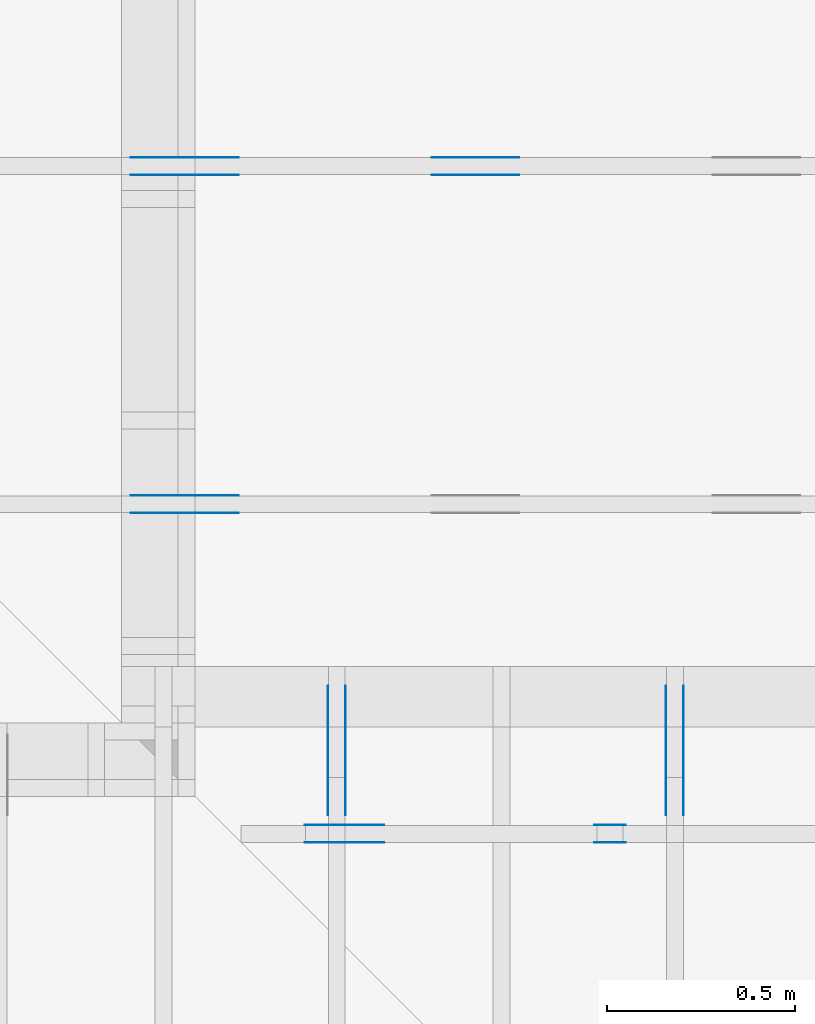
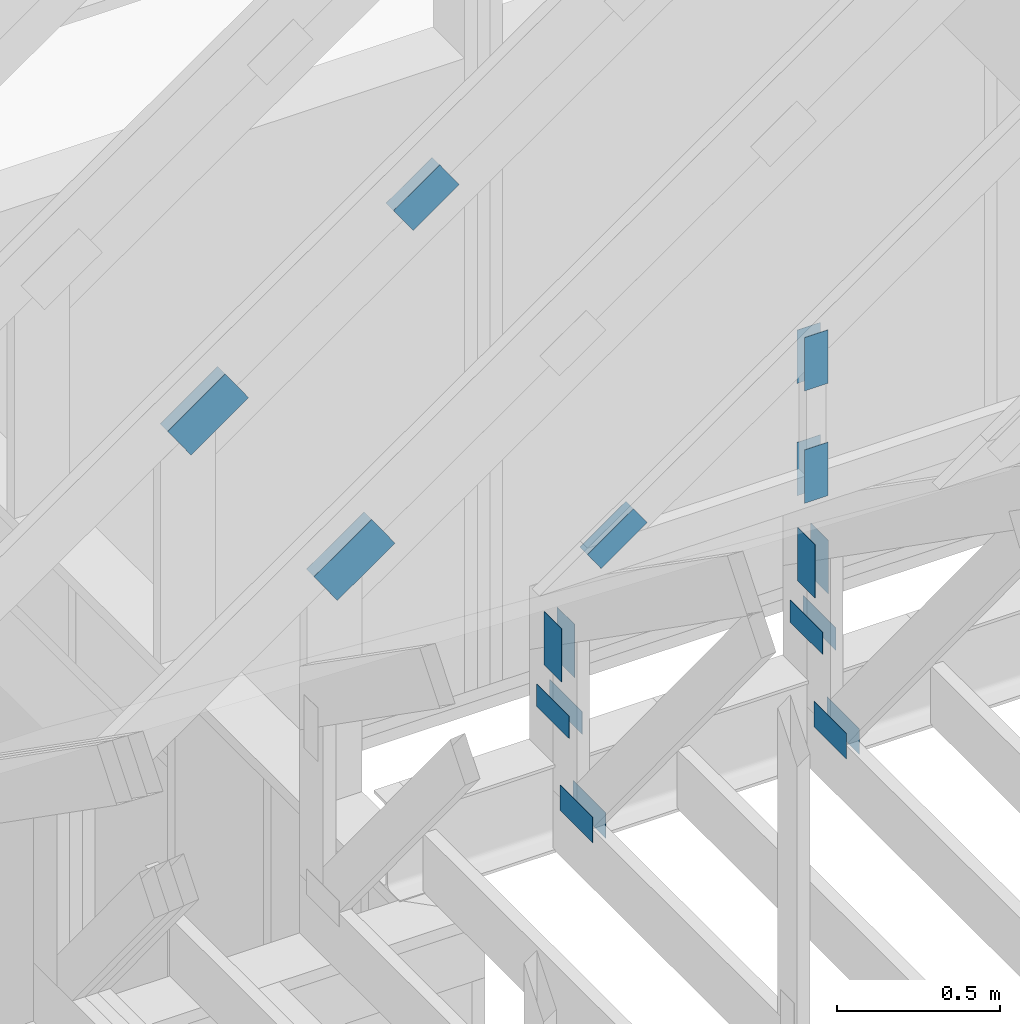
# One storey, part 61 of 70: 24 plates, 5 elements without a shape of their own.
"""IFC2X3 building model written with IfcOpenShell, lengths in millimetres."""

from ifc_helpers import new_model, si_unit, frame, origin, origin_with_axes, origin_2d, place, context, project, spatial, faceted_brep, element, aggregate, save


model = new_model("IFC2X3")

# Units and contexts
model_context = context("Model", 3, precision=1e-05, world=origin())
plan_context = context("Plan", 2, precision=1e-05, world=origin_2d())
ifc_project = project(units=[si_unit("LENGTHUNIT", "METRE", prefix="MILLI"), si_unit("AREAUNIT", "SQUARE_METRE"), si_unit("VOLUMEUNIT", "CUBIC_METRE"), si_unit("SOLIDANGLEUNIT", "STERADIAN"), si_unit("PLANEANGLEUNIT", "RADIAN"), si_unit("MASSUNIT", "GRAM"), si_unit("TIMEUNIT", "SECOND"), si_unit("THERMODYNAMICTEMPERATUREUNIT", "DEGREE_CELSIUS"), si_unit("LUMINOUSINTENSITYUNIT", "LUMEN")], contexts=[model_context, plan_context])

# Site, building, storey
site_placement = place(None, origin_with_axes())
site = spatial("IfcSite", under=ifc_project, at=site_placement, CompositionType="ELEMENT")
building_placement = place(site_placement, origin_with_axes())
building = spatial("IfcBuilding", under=site, at=building_placement, Name="Layout 1", CompositionType="ELEMENT")
storey_placement = place(building_placement, origin_with_axes())
storey = spatial("IfcBuildingStorey", under=building, at=storey_placement, Name="Storey 1", CompositionType="ELEMENT", Elevation=0.0)

# Assembly, plates
assembly_1_placement = place(storey_placement, frame((7000.0, 9505.0, 1.3776821480501744e-15), z_axis=(1.2246063538223773e-16, 1.0, 6.123031769111886e-17), x_axis=(-1.0, 1.2246063538223773e-16, 0.0)))
assembly_1 = element("IfcElementAssembly", 1, at=assembly_1_placement, inside=storey, Name="T4", AssemblyPlace="FACTORY", PredefinedType="TRUSS")
plate_1_placement = place(assembly_1_placement, frame((-24.003422903940475, 866.6521032421275, 0.0), z_axis=(0.0, 0.0, 1.0), x_axis=(-0.819152044288719, 0.5735764363514356, 0.0)))
plate_1 = element("IfcPlate", 2, at=plate_1_placement, context=model_context, shape_type="Brep", body=[
    faceted_brep([(250.0000000000001, 144.0, 1.3), (0.0, 144.0, 1.3), (0.0, 0.0, 1.3), (250.0, 0.0, 1.3), (0.0, 144.0, 0.0), (250.0000000000001, 144.0, 3.0615158845559444e-14), (250.0, 0.0, 3.061515884555943e-14), (0.0, 0.0, 0.0), (250.0, -4.592273826833915e-14, 2.8118638534165077e-30), (250.0, -4.5843138855340694e-14, 1.3), (1.4621692037765842e-32, 7.959941299845453e-17, 1.3), (0.0, 0.0, 0.0), (250.0, 143.9999999999999, -6.310887241768095e-30), (250.0, 143.9999999999999, 1.3), (250.0, 0.0, 1.3), (250.0, 0.0, 0.0), (0.0, 144.0, 0.0), (0.0, 144.0, 1.3), (250.00000000000009, 143.9999999999999, 1.3), (250.00000000000009, 143.9999999999999, -1.5777218104420236e-30), (0.0, 0.0, 0.0), (7.959941299845453e-17, -9.747794691843893e-33, 1.3), (1.7713930908040686e-14, 144.0, 1.3), (1.7634331495042233e-14, 144.0, -1.079755719711939e-30)], [[[0, 1, 2, 3]], [[4, 5, 6, 7]], [[8, 9, 10, 11]], [[12, 13, 14, 15]], [[16, 17, 18, 19]], [[20, 21, 22, 23]]]),
])
plate_2_placement = place(assembly_1_placement, frame((-24.003422903940475, 866.6521032421275, -46.3), z_axis=(0.0, 0.0, 1.0), x_axis=(-0.819152044288719, 0.5735764363514356, 0.0)))
plate_2 = element("IfcPlate", 3, at=plate_2_placement, context=model_context, shape_type="Brep", body=[
    faceted_brep([(250.0000000000001, 144.0, 1.2999999999999972), (0.0, 144.0, 1.2999999999999972), (0.0, 0.0, 1.2999999999999972), (250.0, 0.0, 1.2999999999999972), (0.0, 144.0, 0.0), (250.0000000000001, 144.0, 3.0615158845559444e-14), (250.0, 0.0, 3.061515884555943e-14), (0.0, 0.0, 0.0), (250.0, -4.592273826833915e-14, 2.8118638534165077e-30), (250.0, -4.5843138855340694e-14, 1.2999999999999972), (1.462169203776581e-32, 7.959941299845434e-17, 1.2999999999999972), (0.0, 0.0, 0.0), (250.0, 143.9999999999999, -6.310887241768095e-30), (250.0, 143.9999999999999, 1.2999999999999972), (250.0, 0.0, 1.2999999999999972), (250.0, 0.0, 0.0), (0.0, 144.0, 0.0), (0.0, 144.0, 1.2999999999999972), (250.00000000000009, 143.9999999999999, 1.2999999999999972), (250.00000000000009, 143.9999999999999, -1.5777218104420236e-30), (0.0, 0.0, 0.0), (7.959941299845434e-17, -9.747794691843873e-33, 1.2999999999999972), (1.7713930908040686e-14, 144.0, 1.2999999999999972), (1.7634331495042233e-14, 144.0, -1.079755719711939e-30)], [[[0, 1, 2, 3]], [[4, 5, 6, 7]], [[8, 9, 10, 11]], [[12, 13, 14, 15]], [[16, 17, 18, 19]], [[20, 21, 22, 23]]]),
])
plate_3_placement = place(assembly_1_placement, frame((-1058.7796737620245, 1430.0679887373412, 0.0), z_axis=(0.0, 0.0, 1.0), x_axis=(0.819152044288992, -0.5735764363510462, 0.0)))
plate_3 = element("IfcPlate", 4, at=plate_3_placement, context=model_context, shape_type="Brep", body=[
    faceted_brep([(200.00000000000023, 120.0, 1.3), (0.0, 120.0, 1.3), (2.2737367544323206e-13, 0.0, 1.3), (200.0, 0.0, 1.3), (0.0, 120.0, 0.0), (200.00000000000023, 120.0, 2.4492127076447574e-14), (200.0, 0.0, 2.4492127076447545e-14), (2.2737367544323206e-13, 0.0, 2.78443247639729e-29), (200.0, -3.673819061467132e-14, 2.249491082733206e-30), (200.0, -3.6658591201672864e-14, 1.3), (2.2737367544323206e-13, 7.959941299841276e-17, 1.3), (2.2737367544323206e-13, -4.176648714595935e-29, 2.5573752767891235e-45), (200.0, 120.0, -1.4199496293978212e-29), (200.0, 120.0, 1.3), (200.0, 0.0, 1.3), (200.0, 0.0, 0.0), (0.0, 120.0, 0.0), (-4.8738973459219465e-33, 120.0, 1.3), (200.00000000000023, 119.99999999999999, 1.3), (200.00000000000023, 119.99999999999999, 0.0), (2.2737367544323206e-13, 0.0, 0.0), (2.274532748562305e-13, 1.669984074232364e-31, 1.3), (-2.430497480793855e-14, 120.0, 1.3), (-2.4384574220936983e-14, 120.0, 1.4930752263106387e-30)], [[[0, 1, 2, 3]], [[4, 5, 6, 7]], [[8, 9, 10, 11]], [[12, 13, 14, 15]], [[16, 17, 18, 19]], [[20, 21, 22, 23]]]),
])
plate_4_placement = place(assembly_1_placement, frame((-1058.7796737620245, 1430.0679887373412, -46.300000000000004), z_axis=(0.0, 0.0, 1.0), x_axis=(0.819152044288992, -0.5735764363510462, 0.0)))
plate_4 = element("IfcPlate", 5, at=plate_4_placement, context=model_context, shape_type="Brep", body=[
    faceted_brep([(200.00000000000023, 120.0, 1.2999999999999972), (0.0, 120.0, 1.2999999999999972), (2.2737367544323206e-13, 0.0, 1.2999999999999972), (200.0, 0.0, 1.2999999999999972), (0.0, 120.0, 0.0), (200.00000000000023, 120.0, 2.4492127076447574e-14), (200.0, 0.0, 2.4492127076447545e-14), (2.2737367544323206e-13, 0.0, 2.78443247639729e-29), (200.0, -3.673819061467132e-14, 2.249491082733206e-30), (200.0, -3.6658591201672864e-14, 1.2999999999999972), (2.2737367544323206e-13, 7.959941299841258e-17, 1.2999999999999972), (2.2737367544323206e-13, -4.176648714595935e-29, 2.5573752767891235e-45), (200.0, 120.0, -1.4199496293978212e-29), (200.0, 120.0, 1.2999999999999972), (200.0, 0.0, 1.2999999999999972), (200.0, 0.0, 0.0), (0.0, 120.0, 0.0), (-4.873897345921936e-33, 120.0, 1.2999999999999972), (200.00000000000023, 119.99999999999999, 1.2999999999999972), (200.00000000000023, 119.99999999999999, 0.0), (2.2737367544323206e-13, 0.0, 0.0), (2.274532748562305e-13, 1.669984074232364e-31, 1.2999999999999972), (-2.430497480793855e-14, 120.0, 1.2999999999999972), (-2.4384574220936983e-14, 120.0, 1.4930752263106387e-30)], [[[0, 1, 2, 3]], [[4, 5, 6, 7]], [[8, 9, 10, 11]], [[12, 13, 14, 15]], [[16, 17, 18, 19]], [[20, 21, 22, 23]]]),
])
aggregate(assembly_1, [plate_1, plate_2, plate_3, plate_4])

assembly_2_placement = place(storey_placement, frame((7000.0, 8605.0, 1.3776821480501744e-15), z_axis=(1.2246063538223773e-16, 1.0, 6.123031769111886e-17), x_axis=(-1.0, 1.2246063538223773e-16, 0.0)))
assembly_2 = element("IfcElementAssembly", 6, at=assembly_2_placement, inside=storey, Name="T4", AssemblyPlace="FACTORY", PredefinedType="TRUSS")
plate_5_placement = place(assembly_2_placement, frame((-24.003422903940475, 866.6521032421275, 0.0), z_axis=(0.0, 0.0, 1.0), x_axis=(-0.819152044288719, 0.5735764363514356, 0.0)))
plate_5 = element("IfcPlate", 7, at=plate_5_placement, context=model_context, shape_type="Brep", body=[
    faceted_brep([(250.0000000000001, 144.0, 1.3), (0.0, 144.0, 1.3), (0.0, 0.0, 1.3), (250.0, 0.0, 1.3), (0.0, 144.0, 0.0), (250.0000000000001, 144.0, 3.0615158845559444e-14), (250.0, 0.0, 3.061515884555943e-14), (0.0, 0.0, 0.0), (250.0, -4.592273826833915e-14, 2.8118638534165077e-30), (250.0, -4.5843138855340694e-14, 1.3), (1.4621692037765842e-32, 7.959941299845453e-17, 1.3), (0.0, 0.0, 0.0), (250.0, 143.9999999999999, -6.310887241768095e-30), (250.0, 143.9999999999999, 1.3), (250.0, 0.0, 1.3), (250.0, 0.0, 0.0), (0.0, 144.0, 0.0), (0.0, 144.0, 1.3), (250.00000000000009, 143.9999999999999, 1.3), (250.00000000000009, 143.9999999999999, -1.5777218104420236e-30), (0.0, 0.0, 0.0), (7.959941299845453e-17, -9.747794691843893e-33, 1.3), (1.7713930908040686e-14, 144.0, 1.3), (1.7634331495042233e-14, 144.0, -1.079755719711939e-30)], [[[0, 1, 2, 3]], [[4, 5, 6, 7]], [[8, 9, 10, 11]], [[12, 13, 14, 15]], [[16, 17, 18, 19]], [[20, 21, 22, 23]]]),
])
plate_6_placement = place(assembly_2_placement, frame((-24.003422903940475, 866.6521032421275, -46.3), z_axis=(0.0, 0.0, 1.0), x_axis=(-0.819152044288719, 0.5735764363514356, 0.0)))
plate_6 = element("IfcPlate", 8, at=plate_6_placement, context=model_context, shape_type="Brep", body=[
    faceted_brep([(250.0000000000001, 144.0, 1.2999999999999972), (0.0, 144.0, 1.2999999999999972), (0.0, 0.0, 1.2999999999999972), (250.0, 0.0, 1.2999999999999972), (0.0, 144.0, 0.0), (250.0000000000001, 144.0, 3.0615158845559444e-14), (250.0, 0.0, 3.061515884555943e-14), (0.0, 0.0, 0.0), (250.0, -4.592273826833915e-14, 2.8118638534165077e-30), (250.0, -4.5843138855340694e-14, 1.2999999999999972), (1.462169203776581e-32, 7.959941299845434e-17, 1.2999999999999972), (0.0, 0.0, 0.0), (250.0, 143.9999999999999, -6.310887241768095e-30), (250.0, 143.9999999999999, 1.2999999999999972), (250.0, 0.0, 1.2999999999999972), (250.0, 0.0, 0.0), (0.0, 144.0, 0.0), (0.0, 144.0, 1.2999999999999972), (250.00000000000009, 143.9999999999999, 1.2999999999999972), (250.00000000000009, 143.9999999999999, -1.5777218104420236e-30), (0.0, 0.0, 0.0), (7.959941299845434e-17, -9.747794691843873e-33, 1.2999999999999972), (1.7713930908040686e-14, 144.0, 1.2999999999999972), (1.7634331495042233e-14, 144.0, -1.079755719711939e-30)], [[[0, 1, 2, 3]], [[4, 5, 6, 7]], [[8, 9, 10, 11]], [[12, 13, 14, 15]], [[16, 17, 18, 19]], [[20, 21, 22, 23]]]),
])
aggregate(assembly_2, [plate_5, plate_6])

assembly_3_placement = place(storey_placement, frame((8450.0, 8000.0, -9.081170196248781e-13), z_axis=(-1.0, 1.836909530733566e-16, 6.123031769111886e-17), x_axis=(-1.836909530733566e-16, -1.0, 0.0)))
assembly_3 = element("IfcElementAssembly", 9, at=assembly_3_placement, inside=storey, Name="T3", AssemblyPlace="FACTORY", PredefinedType="TRUSS")
plate_7_placement = place(assembly_3_placement, frame((100.0, 559.2244775947038, 0.0), z_axis=(0.0, 0.0, 1.0), x_axis=(-1.0, 1.2246063538223773e-16, 0.0)))
plate_7 = element("IfcPlate", 10, at=plate_7_placement, context=model_context, shape_type="Brep", body=[
    faceted_brep([(200.0, 84.0, 1.3), (0.0, 84.0, 1.3), (0.0, 0.0, 1.3), (200.0, 0.0, 1.3), (0.0, 84.0, 0.0), (200.0, 84.0, 2.4492127076447545e-14), (200.0, 0.0, 2.4492127076447545e-14), (0.0, 0.0, 0.0), (200.0, -3.673819061467132e-14, 2.249491082733206e-30), (200.0, -3.6658591201672864e-14, 1.3), (1.4621692037765842e-32, 7.959941299845453e-17, 1.3), (0.0, 0.0, 0.0), (200.0, 84.0, 0.0), (200.0, 84.0, 1.3), (200.0, 0.0, 1.3), (200.0, 0.0, 0.0), (0.0, 84.0, 0.0), (-4.8738973459219465e-33, 84.0, 1.3), (200.0, 83.99999999999999, 1.3), (200.0, 83.99999999999999, -7.888609052210118e-31), (0.0, 0.0, 0.0), (7.959941299845453e-17, -9.747794691843893e-33, 1.3), (1.0366292785106424e-14, 84.0, 1.3), (1.0286693372107969e-14, 84.0, -6.298575031652977e-31)], [[[0, 1, 2, 3]], [[4, 5, 6, 7]], [[8, 9, 10, 11]], [[12, 13, 14, 15]], [[16, 17, 18, 19]], [[20, 21, 22, 23]]]),
])
plate_8_placement = place(assembly_3_placement, frame((100.0, 559.2244775947038, -46.3), z_axis=(0.0, 0.0, 1.0), x_axis=(-1.0, 1.2246063538223773e-16, 0.0)))
plate_8 = element("IfcPlate", 11, at=plate_8_placement, context=model_context, shape_type="Brep", body=[
    faceted_brep([(200.0, 84.0, 1.2999999999999972), (0.0, 84.0, 1.2999999999999972), (0.0, 0.0, 1.2999999999999972), (200.0, 0.0, 1.2999999999999972), (0.0, 84.0, 0.0), (200.0, 84.0, 2.4492127076447545e-14), (200.0, 0.0, 2.4492127076447545e-14), (0.0, 0.0, 0.0), (200.0, -3.673819061467132e-14, 2.249491082733206e-30), (200.0, -3.6658591201672864e-14, 1.2999999999999972), (1.462169203776581e-32, 7.959941299845434e-17, 1.2999999999999972), (0.0, 0.0, 0.0), (200.0, 84.0, 0.0), (200.0, 84.0, 1.2999999999999972), (200.0, 0.0, 1.2999999999999972), (200.0, 0.0, 0.0), (0.0, 84.0, 0.0), (-4.873897345921936e-33, 84.0, 1.2999999999999972), (200.0, 83.99999999999999, 1.2999999999999972), (200.0, 83.99999999999999, -7.888609052210118e-31), (0.0, 0.0, 0.0), (7.959941299845434e-17, -9.747794691843873e-33, 1.2999999999999972), (1.0366292785106424e-14, 84.0, 1.2999999999999972), (1.0286693372107969e-14, 84.0, -6.298575031652977e-31)], [[[0, 1, 2, 3]], [[4, 5, 6, 7]], [[8, 9, 10, 11]], [[12, 13, 14, 15]], [[16, 17, 18, 19]], [[20, 21, 22, 23]]]),
])
plate_9_placement = place(assembly_3_placement, frame((54.00000000004449, 658.8550844100489, 0.0), z_axis=(0.0, 0.0, 1.0), x_axis=(6.123031769111886e-17, 1.0, 0.0)))
plate_9 = element("IfcPlate", 12, at=plate_9_placement, context=model_context, shape_type="Brep", body=[
    faceted_brep([(200.0, 108.0, 1.3), (0.0, 108.0, 1.3), (0.0, 7.105427357601002e-15, 1.3), (200.0, 7.105427357601002e-15, 1.3), (0.0, 108.0, 0.0), (200.0, 108.0, 2.4492127076447545e-14), (200.0, 0.0, 2.4492127076447545e-14), (0.0, 0.0, 0.0), (200.0, -2.9632763257070316e-14, 1.8144235082961296e-30), (200.0, -2.955316384407186e-14, 1.3), (1.4621692037765823e-32, 7.185026770599457e-15, 1.3), (0.0, 7.105427357601002e-15, 0.0), (200.0, 108.0, 0.0), (200.0, 108.0, 1.3), (200.0, 0.0, 1.3), (200.0, 0.0, 0.0), (0.0, 108.0, 0.0), (-4.8738973459219465e-33, 108.0, 1.3), (200.0, 107.99999999999999, 1.3), (200.0, 107.99999999999999, -7.888609052210118e-31), (8.701351488741532e-31, 7.105427357601002e-15, -5.327865159977341e-47), (7.95994129984554e-17, 7.105427357601002e-15, 1.3), (1.330534803428013e-14, 108.0, 1.3), (1.3225748621281674e-14, 108.0, -8.098167897839542e-31)], [[[0, 1, 2, 3]], [[4, 5, 6, 7]], [[8, 9, 10, 11]], [[12, 13, 14, 15]], [[16, 17, 18, 19]], [[20, 21, 22, 23]]]),
])
plate_10_placement = place(assembly_3_placement, frame((54.00000000004449, 658.8550844100489, -46.3), z_axis=(0.0, 0.0, 1.0), x_axis=(6.123031769111886e-17, 1.0, 0.0)))
plate_10 = element("IfcPlate", 13, at=plate_10_placement, context=model_context, shape_type="Brep", body=[
    faceted_brep([(200.0, 108.0, 1.2999999999999972), (0.0, 108.0, 1.2999999999999972), (0.0, 7.105427357601002e-15, 1.2999999999999972), (200.0, 7.105427357601002e-15, 1.2999999999999972), (0.0, 108.0, 0.0), (200.0, 108.0, 2.4492127076447545e-14), (200.0, 0.0, 2.4492127076447545e-14), (0.0, 0.0, 0.0), (200.0, -2.9632763257070316e-14, 1.8144235082961296e-30), (200.0, -2.955316384407186e-14, 1.2999999999999972), (1.4621692037765823e-32, 7.185026770599457e-15, 1.2999999999999972), (0.0, 7.105427357601002e-15, 0.0), (200.0, 108.0, 0.0), (200.0, 108.0, 1.2999999999999972), (200.0, 0.0, 1.2999999999999972), (200.0, 0.0, 0.0), (0.0, 108.0, 0.0), (-4.873897345921936e-33, 108.0, 1.2999999999999972), (200.0, 107.99999999999999, 1.2999999999999972), (200.0, 107.99999999999999, -7.888609052210118e-31), (8.701351488741532e-31, 7.105427357601002e-15, -5.327865159977341e-47), (7.959941299845522e-17, 7.105427357601002e-15, 1.2999999999999972), (1.330534803428013e-14, 108.0, 1.2999999999999972), (1.3225748621281674e-14, 108.0, -8.098167897839542e-31)], [[[0, 1, 2, 3]], [[4, 5, 6, 7]], [[8, 9, 10, 11]], [[12, 13, 14, 15]], [[16, 17, 18, 19]], [[20, 21, 22, 23]]]),
])
plate_11_placement = place(assembly_3_placement, frame((44.999999998137355, 172.00000000000097, 0.0), z_axis=(0.0, 0.0, 1.0), x_axis=(1.0, 0.0, 0.0)))
plate_11 = element("IfcPlate", 14, at=plate_11_placement, context=model_context, shape_type="Brep", body=[
    faceted_brep([(200.0, 96.0, 1.3), (0.0, 96.0, 1.3), (0.0, 0.0, 1.3), (200.0, 0.0, 1.3), (0.0, 96.0, 0.0), (200.0, 96.0, 2.4492127076447545e-14), (200.0, 0.0, 2.4492127076447545e-14), (0.0, 0.0, 0.0), (200.0, -3.673819061467132e-14, 2.249491082733206e-30), (200.0, -3.6658591201672864e-14, 1.3), (1.4621692037765842e-32, 7.959941299845453e-17, 1.3), (0.0, 0.0, 0.0), (200.0, 96.0, 0.0), (200.0, 96.0, 1.3), (200.0, 0.0, 1.3), (200.0, 0.0, 0.0), (0.0, 96.0, 0.0), (-4.8738973459219465e-33, 96.0, 1.3), (200.0, 95.99999999999999, 1.3), (200.0, 95.99999999999999, -7.888609052210118e-31), (0.0, 0.0, 0.0), (7.959941299845453e-17, -9.747794691843893e-33, 1.3), (1.1835820409693277e-14, 96.0, 1.3), (1.1756220996694822e-14, 96.0, -7.19837146474626e-31)], [[[0, 1, 2, 3]], [[4, 5, 6, 7]], [[8, 9, 10, 11]], [[12, 13, 14, 15]], [[16, 17, 18, 19]], [[20, 21, 22, 23]]]),
])
plate_12_placement = place(assembly_3_placement, frame((44.999999998137355, 172.00000000000097, -46.3), z_axis=(0.0, 0.0, 1.0), x_axis=(1.0, 0.0, 0.0)))
plate_12 = element("IfcPlate", 15, at=plate_12_placement, context=model_context, shape_type="Brep", body=[
    faceted_brep([(200.0, 96.0, 1.2999999999999972), (0.0, 96.0, 1.2999999999999972), (0.0, 0.0, 1.2999999999999972), (200.0, 0.0, 1.2999999999999972), (0.0, 96.0, 0.0), (200.0, 96.0, 2.4492127076447545e-14), (200.0, 0.0, 2.4492127076447545e-14), (0.0, 0.0, 0.0), (200.0, -3.673819061467132e-14, 2.249491082733206e-30), (200.0, -3.6658591201672864e-14, 1.2999999999999972), (1.462169203776581e-32, 7.959941299845434e-17, 1.2999999999999972), (0.0, 0.0, 0.0), (200.0, 96.0, 0.0), (200.0, 96.0, 1.2999999999999972), (200.0, 0.0, 1.2999999999999972), (200.0, 0.0, 0.0), (0.0, 96.0, 0.0), (-4.873897345921936e-33, 96.0, 1.2999999999999972), (200.0, 95.99999999999999, 1.2999999999999972), (200.0, 95.99999999999999, -7.888609052210118e-31), (0.0, 0.0, 0.0), (7.959941299845434e-17, -9.747794691843873e-33, 1.2999999999999972), (1.1835820409693277e-14, 96.0, 1.2999999999999972), (1.1756220996694822e-14, 96.0, -7.19837146474626e-31)], [[[0, 1, 2, 3]], [[4, 5, 6, 7]], [[8, 9, 10, 11]], [[12, 13, 14, 15]], [[16, 17, 18, 19]], [[20, 21, 22, 23]]]),
])
aggregate(assembly_3, [plate_7, plate_8, plate_9, plate_10, plate_11, plate_12])

assembly_4_placement = place(storey_placement, frame((7550.000000000001, 8000.0, -9.081170196248781e-13), z_axis=(-1.0, 1.836909530733566e-16, 6.123031769111886e-17), x_axis=(-1.836909530733566e-16, -1.0, 0.0)))
assembly_4 = element("IfcElementAssembly", 16, at=assembly_4_placement, inside=storey, Name="T3", AssemblyPlace="FACTORY", PredefinedType="TRUSS")
plate_13_placement = place(assembly_4_placement, frame((100.0, 559.2244775947038, 0.0), z_axis=(0.0, 0.0, 1.0), x_axis=(-1.0, 1.2246063538223773e-16, 0.0)))
plate_13 = element("IfcPlate", 17, at=plate_13_placement, context=model_context, shape_type="Brep", body=[
    faceted_brep([(200.0, 84.0, 1.3), (0.0, 84.0, 1.3), (0.0, 0.0, 1.3), (200.0, 0.0, 1.3), (0.0, 84.0, 0.0), (200.0, 84.0, 2.4492127076447545e-14), (200.0, 0.0, 2.4492127076447545e-14), (0.0, 0.0, 0.0), (200.0, -3.673819061467132e-14, 2.249491082733206e-30), (200.0, -3.6658591201672864e-14, 1.3), (1.4621692037765842e-32, 7.959941299845453e-17, 1.3), (0.0, 0.0, 0.0), (200.0, 84.0, 0.0), (200.0, 84.0, 1.3), (200.0, 0.0, 1.3), (200.0, 0.0, 0.0), (0.0, 84.0, 0.0), (-4.8738973459219465e-33, 84.0, 1.3), (200.0, 83.99999999999999, 1.3), (200.0, 83.99999999999999, -7.888609052210118e-31), (0.0, 0.0, 0.0), (7.959941299845453e-17, -9.747794691843893e-33, 1.3), (1.0366292785106424e-14, 84.0, 1.3), (1.0286693372107969e-14, 84.0, -6.298575031652977e-31)], [[[0, 1, 2, 3]], [[4, 5, 6, 7]], [[8, 9, 10, 11]], [[12, 13, 14, 15]], [[16, 17, 18, 19]], [[20, 21, 22, 23]]]),
])
plate_14_placement = place(assembly_4_placement, frame((100.0, 559.2244775947038, -46.3), z_axis=(0.0, 0.0, 1.0), x_axis=(-1.0, 1.2246063538223773e-16, 0.0)))
plate_14 = element("IfcPlate", 18, at=plate_14_placement, context=model_context, shape_type="Brep", body=[
    faceted_brep([(200.0, 84.0, 1.2999999999999972), (0.0, 84.0, 1.2999999999999972), (0.0, 0.0, 1.2999999999999972), (200.0, 0.0, 1.2999999999999972), (0.0, 84.0, 0.0), (200.0, 84.0, 2.4492127076447545e-14), (200.0, 0.0, 2.4492127076447545e-14), (0.0, 0.0, 0.0), (200.0, -3.673819061467132e-14, 2.249491082733206e-30), (200.0, -3.6658591201672864e-14, 1.2999999999999972), (1.462169203776581e-32, 7.959941299845434e-17, 1.2999999999999972), (0.0, 0.0, 0.0), (200.0, 84.0, 0.0), (200.0, 84.0, 1.2999999999999972), (200.0, 0.0, 1.2999999999999972), (200.0, 0.0, 0.0), (0.0, 84.0, 0.0), (-4.873897345921936e-33, 84.0, 1.2999999999999972), (200.0, 83.99999999999999, 1.2999999999999972), (200.0, 83.99999999999999, -7.888609052210118e-31), (0.0, 0.0, 0.0), (7.959941299845434e-17, -9.747794691843873e-33, 1.2999999999999972), (1.0366292785106424e-14, 84.0, 1.2999999999999972), (1.0286693372107969e-14, 84.0, -6.298575031652977e-31)], [[[0, 1, 2, 3]], [[4, 5, 6, 7]], [[8, 9, 10, 11]], [[12, 13, 14, 15]], [[16, 17, 18, 19]], [[20, 21, 22, 23]]]),
])
plate_15_placement = place(assembly_4_placement, frame((54.00000000004449, 658.8550844100489, 0.0), z_axis=(0.0, 0.0, 1.0), x_axis=(6.123031769111886e-17, 1.0, 0.0)))
plate_15 = element("IfcPlate", 19, at=plate_15_placement, context=model_context, shape_type="Brep", body=[
    faceted_brep([(200.0, 108.0, 1.3), (0.0, 108.0, 1.3), (0.0, 7.105427357601002e-15, 1.3), (200.0, 7.105427357601002e-15, 1.3), (0.0, 108.0, 0.0), (200.0, 108.0, 2.4492127076447545e-14), (200.0, 0.0, 2.4492127076447545e-14), (0.0, 0.0, 0.0), (200.0, -2.9632763257070316e-14, 1.8144235082961296e-30), (200.0, -2.955316384407186e-14, 1.3), (1.4621692037765823e-32, 7.185026770599457e-15, 1.3), (0.0, 7.105427357601002e-15, 0.0), (200.0, 108.0, 0.0), (200.0, 108.0, 1.3), (200.0, 0.0, 1.3), (200.0, 0.0, 0.0), (0.0, 108.0, 0.0), (-4.8738973459219465e-33, 108.0, 1.3), (200.0, 107.99999999999999, 1.3), (200.0, 107.99999999999999, -7.888609052210118e-31), (8.701351488741532e-31, 7.105427357601002e-15, -5.327865159977341e-47), (7.95994129984554e-17, 7.105427357601002e-15, 1.3), (1.330534803428013e-14, 108.0, 1.3), (1.3225748621281674e-14, 108.0, -8.098167897839542e-31)], [[[0, 1, 2, 3]], [[4, 5, 6, 7]], [[8, 9, 10, 11]], [[12, 13, 14, 15]], [[16, 17, 18, 19]], [[20, 21, 22, 23]]]),
])
plate_16_placement = place(assembly_4_placement, frame((54.00000000004449, 658.8550844100489, -46.3), z_axis=(0.0, 0.0, 1.0), x_axis=(6.123031769111886e-17, 1.0, 0.0)))
plate_16 = element("IfcPlate", 20, at=plate_16_placement, context=model_context, shape_type="Brep", body=[
    faceted_brep([(200.0, 108.0, 1.2999999999999972), (0.0, 108.0, 1.2999999999999972), (0.0, 7.105427357601002e-15, 1.2999999999999972), (200.0, 7.105427357601002e-15, 1.2999999999999972), (0.0, 108.0, 0.0), (200.0, 108.0, 2.4492127076447545e-14), (200.0, 0.0, 2.4492127076447545e-14), (0.0, 0.0, 0.0), (200.0, -2.9632763257070316e-14, 1.8144235082961296e-30), (200.0, -2.955316384407186e-14, 1.2999999999999972), (1.4621692037765823e-32, 7.185026770599457e-15, 1.2999999999999972), (0.0, 7.105427357601002e-15, 0.0), (200.0, 108.0, 0.0), (200.0, 108.0, 1.2999999999999972), (200.0, 0.0, 1.2999999999999972), (200.0, 0.0, 0.0), (0.0, 108.0, 0.0), (-4.873897345921936e-33, 108.0, 1.2999999999999972), (200.0, 107.99999999999999, 1.2999999999999972), (200.0, 107.99999999999999, -7.888609052210118e-31), (8.701351488741532e-31, 7.105427357601002e-15, -5.327865159977341e-47), (7.959941299845522e-17, 7.105427357601002e-15, 1.2999999999999972), (1.330534803428013e-14, 108.0, 1.2999999999999972), (1.3225748621281674e-14, 108.0, -8.098167897839542e-31)], [[[0, 1, 2, 3]], [[4, 5, 6, 7]], [[8, 9, 10, 11]], [[12, 13, 14, 15]], [[16, 17, 18, 19]], [[20, 21, 22, 23]]]),
])
plate_17_placement = place(assembly_4_placement, frame((44.999999998137355, 172.00000000000097, 0.0), z_axis=(0.0, 0.0, 1.0), x_axis=(1.0, 0.0, 0.0)))
plate_17 = element("IfcPlate", 21, at=plate_17_placement, context=model_context, shape_type="Brep", body=[
    faceted_brep([(200.0, 96.0, 1.3), (0.0, 96.0, 1.3), (0.0, 0.0, 1.3), (200.0, 0.0, 1.3), (0.0, 96.0, 0.0), (200.0, 96.0, 2.4492127076447545e-14), (200.0, 0.0, 2.4492127076447545e-14), (0.0, 0.0, 0.0), (200.0, -3.673819061467132e-14, 2.249491082733206e-30), (200.0, -3.6658591201672864e-14, 1.3), (1.4621692037765842e-32, 7.959941299845453e-17, 1.3), (0.0, 0.0, 0.0), (200.0, 96.0, 0.0), (200.0, 96.0, 1.3), (200.0, 0.0, 1.3), (200.0, 0.0, 0.0), (0.0, 96.0, 0.0), (-4.8738973459219465e-33, 96.0, 1.3), (200.0, 95.99999999999999, 1.3), (200.0, 95.99999999999999, -7.888609052210118e-31), (0.0, 0.0, 0.0), (7.959941299845453e-17, -9.747794691843893e-33, 1.3), (1.1835820409693277e-14, 96.0, 1.3), (1.1756220996694822e-14, 96.0, -7.19837146474626e-31)], [[[0, 1, 2, 3]], [[4, 5, 6, 7]], [[8, 9, 10, 11]], [[12, 13, 14, 15]], [[16, 17, 18, 19]], [[20, 21, 22, 23]]]),
])
plate_18_placement = place(assembly_4_placement, frame((44.999999998137355, 172.00000000000097, -46.3), z_axis=(0.0, 0.0, 1.0), x_axis=(1.0, 0.0, 0.0)))
plate_18 = element("IfcPlate", 22, at=plate_18_placement, context=model_context, shape_type="Brep", body=[
    faceted_brep([(200.0, 96.0, 1.2999999999999972), (0.0, 96.0, 1.2999999999999972), (0.0, 0.0, 1.2999999999999972), (200.0, 0.0, 1.2999999999999972), (0.0, 96.0, 0.0), (200.0, 96.0, 2.4492127076447545e-14), (200.0, 0.0, 2.4492127076447545e-14), (0.0, 0.0, 0.0), (200.0, -3.673819061467132e-14, 2.249491082733206e-30), (200.0, -3.6658591201672864e-14, 1.2999999999999972), (1.462169203776581e-32, 7.959941299845434e-17, 1.2999999999999972), (0.0, 0.0, 0.0), (200.0, 96.0, 0.0), (200.0, 96.0, 1.2999999999999972), (200.0, 0.0, 1.2999999999999972), (200.0, 0.0, 0.0), (0.0, 96.0, 0.0), (-4.873897345921936e-33, 96.0, 1.2999999999999972), (200.0, 95.99999999999999, 1.2999999999999972), (200.0, 95.99999999999999, -7.888609052210118e-31), (0.0, 0.0, 0.0), (7.959941299845434e-17, -9.747794691843873e-33, 1.2999999999999972), (1.1835820409693277e-14, 96.0, 1.2999999999999972), (1.1756220996694822e-14, 96.0, -7.19837146474626e-31)], [[[0, 1, 2, 3]], [[4, 5, 6, 7]], [[8, 9, 10, 11]], [[12, 13, 14, 15]], [[16, 17, 18, 19]], [[20, 21, 22, 23]]]),
])
aggregate(assembly_4, [plate_13, plate_14, plate_15, plate_16, plate_17, plate_18])

assembly_5_placement = place(storey_placement, frame((7294.999999999998, 7682.5, 1206.561223771864), z_axis=(0.0, -1.0, 6.123031769111886e-17), x_axis=(1.0, 0.0, 0.0)))
assembly_5 = element("IfcElementAssembly", 23, at=assembly_5_placement, inside=storey, Name="SB1", AssemblyPlace="FACTORY", PredefinedType="TRUSS")
plate_19_placement = place(assembly_5_placement, frame((240.6595744434396, 43.99264011447589, 0.0), z_axis=(0.0, 0.0, 1.0), x_axis=(0.8191520442889916, 0.5735764363510464, 0.0)))
plate_19 = element("IfcPlate", 24, at=plate_19_placement, context=model_context, shape_type="Brep", body=[
    faceted_brep([(200.00000000000003, 83.99999999999999, 1.3), (0.0, 83.99999999999999, 1.3), (0.0, 0.0, 1.3), (199.99999999999997, 0.0, 1.3), (0.0, 83.99999999999999, 0.0), (200.00000000000003, 83.99999999999999, 2.4492127076447548e-14), (199.99999999999997, 2.842170943040401e-14, 2.4492127076447542e-14), (0.0, 2.842170943040401e-14, 0.0), (199.99999999999997, -3.673819061467131e-14, 3.9897613804815125e-30), (199.99999999999997, -3.665859120167286e-14, 1.3), (1.4621692037765842e-32, 7.959941299845453e-17, 1.3), (0.0, 0.0, 0.0), (199.99999999999997, 84.00000000000003, -3.1554436208840472e-30), (199.99999999999997, 84.00000000000003, 1.3), (199.99999999999997, 2.842170943040401e-14, 1.3), (199.99999999999997, 2.842170943040401e-14, 0.0), (0.0, 83.99999999999999, 0.0), (0.0, 83.99999999999999, 1.3), (200.0, 84.00000000000001, 1.3), (200.0, 84.00000000000001, -7.888609052210118e-31), (0.0, 0.0, 0.0), (7.959941299845453e-17, -9.747794691843893e-33, 1.3), (1.0366292785106422e-14, 83.99999999999999, 1.3), (1.0286693372107967e-14, 83.99999999999999, -6.298575031652976e-31)], [[[0, 1, 2, 3]], [[4, 5, 6, 7]], [[8, 9, 10, 11]], [[12, 13, 14, 15]], [[16, 17, 18, 19]], [[20, 21, 22, 23]]]),
])
plate_20_placement = place(assembly_5_placement, frame((240.6595744434396, 43.99264011447589, -46.3), z_axis=(0.0, 0.0, 1.0), x_axis=(0.8191520442889916, 0.5735764363510464, 0.0)))
plate_20 = element("IfcPlate", 25, at=plate_20_placement, context=model_context, shape_type="Brep", body=[
    faceted_brep([(200.00000000000003, 83.99999999999999, 1.2999999999999972), (0.0, 83.99999999999999, 1.2999999999999972), (0.0, 0.0, 1.2999999999999972), (199.99999999999997, 0.0, 1.2999999999999972), (0.0, 83.99999999999999, 0.0), (200.00000000000003, 83.99999999999999, 2.4492127076447548e-14), (199.99999999999997, 2.842170943040401e-14, 2.4492127076447542e-14), (0.0, 2.842170943040401e-14, 0.0), (199.99999999999997, -3.673819061467131e-14, 3.9897613804815125e-30), (199.99999999999997, -3.665859120167286e-14, 1.2999999999999972), (1.462169203776581e-32, 7.959941299845434e-17, 1.2999999999999972), (0.0, 0.0, 0.0), (199.99999999999997, 84.00000000000003, -3.1554436208840472e-30), (199.99999999999997, 84.00000000000003, 1.2999999999999972), (199.99999999999997, 2.842170943040401e-14, 1.2999999999999972), (199.99999999999997, 2.842170943040401e-14, 0.0), (0.0, 83.99999999999999, 0.0), (0.0, 83.99999999999999, 1.2999999999999972), (200.0, 84.00000000000001, 1.2999999999999972), (200.0, 84.00000000000001, -7.888609052210118e-31), (0.0, 0.0, 0.0), (7.959941299845434e-17, -9.747794691843873e-33, 1.2999999999999972), (1.0366292785106422e-14, 83.99999999999999, 1.2999999999999972), (1.0286693372107967e-14, 83.99999999999999, -6.298575031652976e-31)], [[[0, 1, 2, 3]], [[4, 5, 6, 7]], [[8, 9, 10, 11]], [[12, 13, 14, 15]], [[16, 17, 18, 19]], [[20, 21, 22, 23]]]),
])
plate_21_placement = place(assembly_5_placement, frame((963.0000000000001, 657.2156252501236, 0.0), z_axis=(0.0, 0.0, 1.0), x_axis=(9.49408737391244e-16, -1.0, 0.0)))
plate_21 = element("IfcPlate", 26, at=plate_21_placement, context=model_context, shape_type="Brep", body=[
    faceted_brep([(200.0, 84.0, 1.3), (0.0, 84.0, 1.3), (0.0, 0.0, 1.3), (200.0, 0.0, 1.3), (0.0, 84.0, 0.0), (200.0, 84.0, 2.4492127076447545e-14), (200.0, 0.0, 2.4492127076447545e-14), (0.0, 0.0, 0.0), (200.0, -3.673819061467132e-14, 2.249491082733206e-30), (200.0, -3.6658591201672864e-14, 1.3), (1.4621692037765842e-32, 7.959941299845453e-17, 1.3), (0.0, 0.0, 0.0), (200.0, 84.0, 0.0), (200.0, 84.0, 1.3), (200.0, 0.0, 1.3), (200.0, 0.0, 0.0), (0.0, 84.0, 0.0), (-4.8738973459219465e-33, 84.0, 1.3), (200.0, 83.99999999999999, 1.3), (200.0, 83.99999999999999, -7.888609052210118e-31), (0.0, 0.0, 0.0), (7.959941299845453e-17, -9.747794691843893e-33, 1.3), (1.0366292785106424e-14, 84.0, 1.3), (1.0286693372107969e-14, 84.0, -6.298575031652977e-31)], [[[0, 1, 2, 3]], [[4, 5, 6, 7]], [[8, 9, 10, 11]], [[12, 13, 14, 15]], [[16, 17, 18, 19]], [[20, 21, 22, 23]]]),
])
plate_22_placement = place(assembly_5_placement, frame((963.0000000000001, 657.2156252501236, -46.3), z_axis=(0.0, 0.0, 1.0), x_axis=(9.49408737391244e-16, -1.0, 0.0)))
plate_22 = element("IfcPlate", 27, at=plate_22_placement, context=model_context, shape_type="Brep", body=[
    faceted_brep([(200.0, 84.0, 1.2999999999999972), (0.0, 84.0, 1.2999999999999972), (0.0, 0.0, 1.2999999999999972), (200.0, 0.0, 1.2999999999999972), (0.0, 84.0, 0.0), (200.0, 84.0, 2.4492127076447545e-14), (200.0, 0.0, 2.4492127076447545e-14), (0.0, 0.0, 0.0), (200.0, -3.673819061467132e-14, 2.249491082733206e-30), (200.0, -3.6658591201672864e-14, 1.2999999999999972), (1.462169203776581e-32, 7.959941299845434e-17, 1.2999999999999972), (0.0, 0.0, 0.0), (200.0, 84.0, 0.0), (200.0, 84.0, 1.2999999999999972), (200.0, 0.0, 1.2999999999999972), (200.0, 0.0, 0.0), (0.0, 84.0, 0.0), (-4.873897345921936e-33, 84.0, 1.2999999999999972), (200.0, 83.99999999999999, 1.2999999999999972), (200.0, 83.99999999999999, -7.888609052210118e-31), (0.0, 0.0, 0.0), (7.959941299845434e-17, -9.747794691843873e-33, 1.2999999999999972), (1.0366292785106424e-14, 84.0, 1.2999999999999972), (1.0286693372107969e-14, 84.0, -6.298575031652977e-31)], [[[0, 1, 2, 3]], [[4, 5, 6, 7]], [[8, 9, 10, 11]], [[12, 13, 14, 15]], [[16, 17, 18, 19]], [[20, 21, 22, 23]]]),
])
plate_23_placement = place(assembly_5_placement, frame((1047.0000000000005, 35.75466960929184, 0.0), z_axis=(0.0, 0.0, 1.0), x_axis=(-1.0489927069340377e-15, 1.0, 0.0)))
plate_23 = element("IfcPlate", 28, at=plate_23_placement, context=model_context, shape_type="Brep", body=[
    faceted_brep([(200.0, 84.0, 1.3), (7.105427357601002e-15, 84.0, 1.3), (0.0, 0.0, 1.3), (200.0, 0.0, 1.3), (7.105427357601002e-15, 84.0, 8.701351488741532e-31), (200.0, 84.0, 2.4492127076447545e-14), (200.0, 0.0, 2.4492127076447545e-14), (0.0, 0.0, 0.0), (200.0, -3.673819061467132e-14, 2.249491082733206e-30), (200.0, -3.6658591201672864e-14, 1.3), (1.4621692037765842e-32, 7.959941299845453e-17, 1.3), (0.0, 0.0, 0.0), (200.0, 84.0, 0.0), (200.0, 84.0, 1.3), (200.0, 0.0, 1.3), (200.0, 0.0, 0.0), (7.105427357601002e-15, 84.0, 0.0), (7.105427357601002e-15, 84.0, 1.3), (200.0, 83.99999999999999, 1.3), (200.0, 83.99999999999999, -7.888609052210118e-31), (0.0, 0.0, 0.0), (7.959941299845453e-17, -9.747794691843893e-33, 1.3), (1.0366292785106424e-14, 84.0, 1.3), (1.0286693372107969e-14, 84.0, -1.9478992872822115e-31)], [[[0, 1, 2, 3]], [[4, 5, 6, 7]], [[8, 9, 10, 11]], [[12, 13, 14, 15]], [[16, 17, 18, 19]], [[20, 21, 22, 23]]]),
])
plate_24_placement = place(assembly_5_placement, frame((1047.0000000000005, 35.75466960929184, -46.3), z_axis=(0.0, 0.0, 1.0), x_axis=(-1.0489927069340377e-15, 1.0, 0.0)))
plate_24 = element("IfcPlate", 29, at=plate_24_placement, context=model_context, shape_type="Brep", body=[
    faceted_brep([(200.0, 84.0, 1.2999999999999972), (7.105427357601002e-15, 84.0, 1.2999999999999972), (0.0, 0.0, 1.2999999999999972), (200.0, 0.0, 1.2999999999999972), (7.105427357601002e-15, 84.0, 8.701351488741532e-31), (200.0, 84.0, 2.4492127076447545e-14), (200.0, 0.0, 2.4492127076447545e-14), (0.0, 0.0, 0.0), (200.0, -3.673819061467132e-14, 2.249491082733206e-30), (200.0, -3.6658591201672864e-14, 1.2999999999999972), (1.462169203776581e-32, 7.959941299845434e-17, 1.2999999999999972), (0.0, 0.0, 0.0), (200.0, 84.0, 0.0), (200.0, 84.0, 1.2999999999999972), (200.0, 0.0, 1.2999999999999972), (200.0, 0.0, 0.0), (7.105427357601002e-15, 84.0, 0.0), (7.105427357601002e-15, 84.0, 1.2999999999999972), (200.0, 83.99999999999999, 1.2999999999999972), (200.0, 83.99999999999999, -7.888609052210118e-31), (0.0, 0.0, 0.0), (7.959941299845434e-17, -9.747794691843873e-33, 1.2999999999999972), (1.0366292785106424e-14, 84.0, 1.2999999999999972), (1.0286693372107969e-14, 84.0, -1.9478992872822115e-31)], [[[0, 1, 2, 3]], [[4, 5, 6, 7]], [[8, 9, 10, 11]], [[12, 13, 14, 15]], [[16, 17, 18, 19]], [[20, 21, 22, 23]]]),
])
aggregate(assembly_5, [plate_19, plate_20, plate_21, plate_22, plate_23, plate_24])

save(model, "model.ifc")
